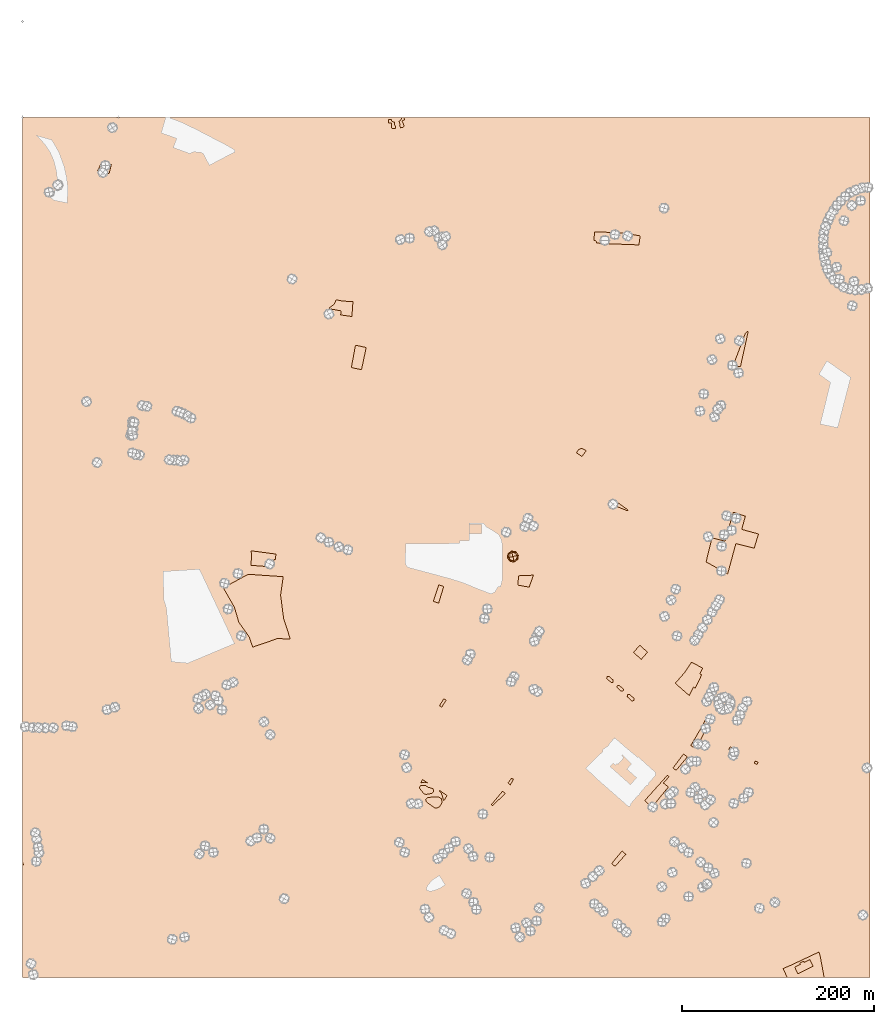
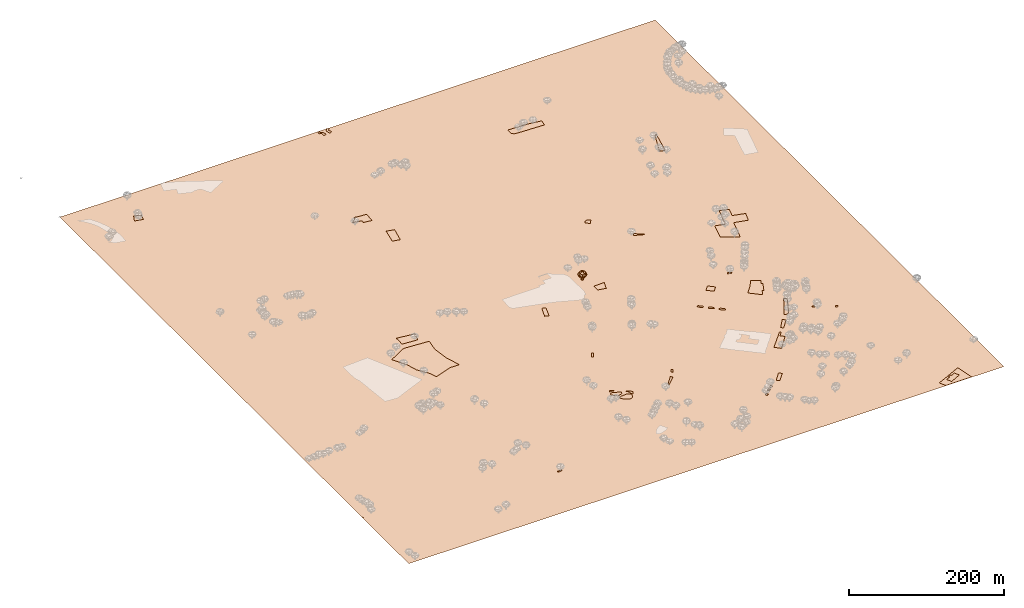
# Not in any storey, part 26 of 92: 3 geographic elements.
"""IFC4 model written with IfcOpenShell, lengths in metres."""

from ifc_helpers import new_model, si_unit, origin_with_axes, place, context, subcontext, project, spatial, triangles, material, element, save


model = new_model("IFC4")

# Units and contexts
model_context = context("Model", 3, precision=1e-05, world=origin_with_axes())
body_context = subcontext(model_context, "Body", "Model", "MODEL_VIEW")
ifc_project = project(units=[si_unit("VOLUMEUNIT", "CUBIC_METRE"), si_unit("LENGTHUNIT", "METRE"), si_unit("AREAUNIT", "SQUARE_METRE")], contexts=[model_context])

# Site
site_placement = place(None, origin_with_axes())
site = spatial("IfcSite", under=ifc_project, at=site_placement)

# Geographic elements
ifc_material_1 = material(Name="garden")
geographic_element_1_placement = place(site_placement, origin_with_axes())
element("IfcGeographicElement", 1, at=geographic_element_1_placement, inside=site, material=ifc_material_1, Name="cw_surface_garden", context=body_context, shape_type="Tessellation", body=[
    triangles([(388.47952636224693, -8.882966585345057, 0.0), (385.2042061517901, -3.819002392627082, 0.0), (385.13451909391256, -5.839946064550666, 0.0), (385.5526414411779, -11.438196694471047, 0.0), (385.85461869198065, -4.353250842880523, 0.0), (384.8557613656651, -3.098883801084529, 0.0), (389.4319256499774, -11.438196694471047, 0.0), (386.7141019025411, -4.794621202912855, 0.0), (381.99857299921086, -2.1000169780317557, 0.0), (386.04046034305804, -11.92598710613945, 0.0), (388.99056478668234, -8.929424623930094, 0.0), (387.92202040248924, -4.91078529284993, 0.0), (384.71638724991, -2.3323071709569394, 0.0), (381.90565692204075, -5.7237819746135905, 0.0), (384.9254579202799, -11.136200450193824, 0.0), (623.1354040214331, -120.67944704737984, 0.0), (616.3292395657398, -120.16839912620719, 0.0), (643.135771776744, -133.17677338760163, 0.0), (644.4366087280466, -123.69923854888171, 0.0), (617.9552857548681, -120.21485716479222, 0.0), (616.3292395657398, -132.16048954844808, 0.0), (643.646814949548, -129.50655035243474, 0.0), (627.734791315384, -121.07434037535265, 0.0), (740.8495293756547, -414.62210676459796, 0.0), (749.2178548013137, -414.62210676459796, 0.0), (741.5812529801062, -412.0669146424209, 0.0), (630.8242793715006, -410.48730334358066, 0.0), (631.7999070849776, -409.8368908033902, 0.0), (620.5337301930213, -401.72990608987783, 0.0), (617.862368787379, -405.3072130478746, 0.0), (757.1912963957373, -223.0274272337283, 0.0), (741.6509400379838, -258.5449206210551, 0.0), (749.0146056308729, -260.3335741000535, 0.0), (754.1482663782056, -237.10434587931582, 0.0), (754.2876404939607, -225.04837090565186, 0.0), (596.6366580932153, -119.58767364389423, 0.0), (598.9828080352341, -130.0175982736074, 0.0), (628.228428226632, -132.61346492138944, 0.0), (623.1412160211471, -120.67944704737984, 0.0), (597.7981090578412, -128.71675419975188, 0.0), (598.7040598037239, -131.13260069638554, 0.0), (627.7405998280146, -121.07434037535265, 0.0), (617.961087738492, -120.21485716479222, 0.0), (596.357909861705, -128.50769302611923, 0.0), (605.6960515911954, -131.7597842172835, 0.0), (628.228428226632, -121.14983943642196, 0.0), (577.9371266214677, -350.02165330134426, 0.0), (588.1347610582557, -347.8380875008986, 0.0), (583.465671200036, -345.3525634431246, 0.0), (580.2832765634864, -346.6069304849206, 0.0), (583.6979613929611, -353.9473765552544, 0.0), (332.49707704346656, -201.9817458199618, 0.0), (333.7282340594445, -191.71442432529625, 0.0), (323.8558058927518, -196.03505990065364, 0.0), (322.5549713156335, -197.1268428008765, 0.0), (332.31124488912644, -203.53810910603502, 0.0), (325.6909174103352, -194.0605742673151, 0.0), (320.3714245086623, -198.5438319711946, 0.0), (343.64711076798505, -207.92843173926997, 0.0), (327.1078970839161, -190.41359924491522, 0.0), (319.8836103551508, -199.8214280322831, 0.0), (331.753748426106, -206.2094653181491, 0.0), (344.71565515217816, -192.38808487825378, 0.0), (358.5138160695182, -240.2635304900473, 0.0), (345.3893062083984, -248.69574046712938, 0.0), (343.06637578893486, -261.12336075599916, 0.0), (353.6821420697254, -263.3766136143224, 0.0), (347.34056282244444, -237.80121645809137, 0.0), (628.228428226632, -409.4478284720836, 0.0), (628.228428226632, -407.2642626716379, 0.0), (620.539527873436, -401.72990608987783, 0.0), (617.868171661322, -405.3072130478746, 0.0), (78.25895872576271, -56.125411261577945, 0.0), (91.31378152900494, -54.476136646703274, 0.0), (87.66680650660507, -47.71643030378836, 0.0), (82.92802959050788, -45.90455017968175, 0.0), (90.19878860296406, -58.91291969270757, 0.0), (92.61462560286046, -49.36570491866302, 0.0), (704.5770833645838, -655.1782282548988, 0.0), (718.4913988751237, -626.8385588093836, 0.0), (706.5283399786298, -639.7540264903452, 0.0), (697.2134177716947, -655.5498925635791, 0.0), (711.4529395523299, -641.7052641109168, 0.0), (714.5424276084466, -624.7943861181675, 0.0), (699.9080124998386, -657.2224009461149, 0.0), (678.7694102605334, -678.8952658807793, 0.0), (681.8821273359426, -681.4737250091979, 0.0), (693.6593493297278, -667.3735773443178, 0.0), (689.594232966588, -664.4002248879266, 0.0), (750.4083562851612, -429.99406868635, 0.0), (732.9399723326543, -442.35201853663233, 0.0), (714.519198589154, -458.58925259571424, 0.0), (744.2758382115129, -444.8375449685906, 0.0), (754.078579320328, -416.2423634334106, 0.0), (733.543936330997, -475.22137760858465, 0.0), (763.3935015272631, -449.57630763958196, 0.0), (752.8009642657651, -421.2831069164812, 0.0), (741.5812529801062, -412.0611019738084, 0.0), (719.4670176854095, -438.82117436558923, 0.0), (713.2183640120357, -463.9784325552647, 0.0), (735.6345670607981, -476.5686749726566, 0.0), (767.8767402376682, -434.77928939592636, 0.0), (709.5945990154539, -574.7586227186953, 0.0), (687.3409991017393, -583.3534548242995, 0.0), (700.0241575963012, -594.5267080713733, 0.0), (706.6677140943849, -580.821453734466, 0.0), (689.8032941402207, -580.5194764836633, 0.0), (681.0691069123359, -590.5545077854036, 0.0), (701.9986432296397, -595.5720139395366, 0.0), (690.7324644086586, -579.4044835576224, 0.0), (695.6106011954051, -603.3770403957207, 0.0), (708.5260546312609, -581.8667785961038, 0.0), (697.9799849050851, -568.5331885678769, 0.0), (652.1254829652152, -558.149731473486, 0.0), (644.0184816324127, -550.9486690156447, 0.0), (637.4446098180222, -558.3820216664112, 0.0), (645.5516111508247, -565.5598551049601, 0.0), (656.3764338568793, -719.7787197051014, 0.0), (669.3383429571358, -695.2254183912157, 0.0), (668.7576127264542, -694.6214638896103, 0.0), (657.3752888090105, -703.8202315033454, 0.0), (673.8215864159095, -698.825954368505, 0.0), (674.5184617430536, -688.0475944494041, 0.0), (649.3379769082699, -712.833185956215, 0.0), (658.5832096831431, -717.5254858402526, 0.0), (673.1711643789816, -698.1755418283145, 0.0), (672.869187128179, -686.4912311633308, 0.0), (681.0691069123359, -538.05644934745, 0.0), (679.9773287604817, -540.1935381158362, 0.0), (684.4141141806703, -542.4235429613924, 0.0), (686.667348045519, -540.8671891720564, 0.0), (763.4167305465556, -674.0868209002791, 0.0), (766.413293028765, -675.3179779162571, 0.0), (767.435379374373, -673.0414960386413, 0.0), (764.4620459114562, -671.7406709582602, 0.0), (736.9586306572089, -659.7776120617664, 0.0), (739.9552026361555, -661.0552271163294, 0.0), (741.2095791746888, -658.1515617178156, 0.0), (738.2130071957421, -656.8507366374346, 0.0), (621.9216767086033, -402.7229513411269, 0.0), (617.862368787379, -405.3013959276665, 0.0), (630.8242793715006, -410.48151426842475, 0.0), (631.7999070849776, -409.83109579277345, 0.0), (619.7903948982672, -402.7229513411269, 0.0), (629.4305251559358, -769.001448435861, 0.0), (616.3292395657398, -776.690348789057, 0.0), (616.3292395657398, -780.0121175413616, 0.0), (618.1643487091391, -781.6613969046049, 0.0), (625.5280145988011, -765.6099736322043, 0.0), (635.7024179388852, -608.9056039677636, 0.0), (638.2344035965207, -606.4665379485746, 0.0), (631.1727176286188, -602.401421585435, 0.0), (630.8939670229242, -604.6314264309912, 0.0), (637.9556529908263, -608.7430008327159, 0.0), (633.3330366033896, -602.1691313925097, 0.0), (624.6453040011999, -598.8241146274381, 0.0), (626.8985392015273, -596.6405678204669, 0.0), (620.5569593607003, -593.1329479203476, 0.0), (620.3478964064293, -595.0145174765162, 0.0), (626.6662469311908, -598.8008856081457, 0.0), (622.5314439924298, -592.830970669545, 0.0), (264.2496010741268, -457.31164228951985, 0.0), (248.29112058846985, -453.64142400272164, 0.0), (238.23286382871345, -467.50927672630786, 0.0), (262.29834683426515, -461.12123469207324, 0.0), (261.5085530557666, -455.4068437140589, 0.0), (239.13880389076675, -455.5229935588901, 0.0), (261.3924067722118, -468.0203198991119, 0.0), (263.7385579013228, -461.30707159478203, 0.0), (264.4586646219438, -455.7785127711078, 0.0), (238.11671754515868, -452.2941266386497, 0.0), (260.7419882965605, -469.2282383990601, 0.0), (517.0068582064318, -488.18328908302544, 0.0), (528.667939852123, -490.3203778514116, 0.0), (532.9421173888953, -477.75336445331226, 0.0), (517.3785225151122, -478.42701550953257, 0.0), (508.9463125380301, -696.5727205036562, 0.0), (512.2448712645166, -690.6028055650555, 0.0), (510.2936146504706, -689.6039387420028, 0.0), (506.53047553813366, -694.6679219281953, 0.0), (490.4790712592076, -718.1991273997356, 0.0), (503.6500581523869, -705.5856559630513, 0.0), (500.83930883104324, -703.1930479824474, 0.0), (489.2247042174116, -717.1305925122798, 0.0), (621.9274950147443, -402.7229513411269, 0.0), (617.868171661322, -405.3013959276665, 0.0), (628.228428226632, -409.44200623254056, 0.0), (628.228428226632, -407.2584586094435, 0.0), (619.7961992560754, -402.7229513411269, 0.0), (437.2841422424784, -615.5027024272622, 0.0), (441.9532131072236, -608.3016494661581, 0.0), (439.5373761073272, -606.7917442186699, 0.0), (435.00767935833716, -613.9695681604815, 0.0), (428.5731840338861, -505.16385413365225, 0.0), (434.12495763174695, -506.99896565123566, 0.0), (439.44446003015713, -489.5538107180213, 0.0), (434.24110272820957, -487.83485379363765, 0.0), (601.1199157970948, -789.1179690779268, 0.0), (604.1164782793041, -787.5383957660355, 0.0), (602.536866980464, -784.5882533354622, 0.0), (599.7261366525947, -786.0517005443653, 0.0), (595.2429169356642, -794.7626777464321, 0.0), (598.2394794178736, -793.183066447592, 0.0), (596.6366580932153, -790.2329620039676, 0.0), (593.825927765346, -791.6964092128708, 0.0), (437.9113257633764, -707.7692027700225, 0.0), (438.70113141279654, -710.5799330978917, 0.0), (442.8126868210468, -707.699515712145, 0.0), (436.86601989521307, -705.1907626350785, 0.0), (439.1424827793544, -713.1119341877252, 0.0), (435.28642758984734, -703.2395060210324, 0.0), (439.885811396715, -712.78672791763, 0.0), (435.28642758984734, -702.4961774036718, 0.0), (417.4463698319229, -693.9710513494197, 0.0), (419.7692907546492, -693.7852002016051, 0.0), (417.3766827740453, -691.0209279123209, 0.0), (415.2163649863666, -694.8305250632428, 0.0), (422.41743694094527, -694.4588607545626, 0.0), (420.4197222883142, -697.2463620631393, 0.0), (414.5427234268836, -700.4984627510408, 0.0), (426.83098859347274, -705.4230528280036, 0.0), (423.16076555830585, -699.0582445614302, 0.0), (414.98407479344144, -697.5715683332345, 0.0), (421.0236767899197, -706.468358696167, 0.0), (428.9680773618589, -702.0548070436396, 0.0), (417.4695988512154, -696.967613831629, 0.0), (414.1246010796183, -699.1047026000152, 0.0), (418.7472139057784, -705.8876332138541, 0.0), (424.46160963216136, -705.9340912524391, 0.0), (428.3873518795459, -704.3544989470734, 0.0), (427.89952348092856, -700.4520047124557, 0.0), (420.4197222883142, -711.9040061910398, 0.0), (434.821847203997, -719.5232004928837, 0.0), (434.5895570110718, -709.5113982104359, 0.0), (423.300139674061, -709.6740013454835, 0.0), (430.2456734229474, -720.7543385153872, 0.0), (437.79518066691384, -714.3663012295211, 0.0), (431.8484947476057, -709.0003597860004, 0.0), (421.83669246515785, -710.4870170207216, 0.0), (421.5579442336476, -714.5056753452762, 0.0), (432.73121647419583, -720.6614224382171, 0.0), (436.773103818043, -716.9447413644652, 0.0), (436.88924891450563, -710.9051583614614, 0.0), (628.228428226632, -770.3603555612106, 0.0), (625.5338240017509, -765.6099736322043, 0.0), (614.7554450891755, -778.5951283710435, 0.0), (618.1701679055991, -781.6613969046049, 0.0), (628.228428226632, -767.9503495579804, 0.0), (613.9424484074118, -589.5556599558254, 0.0), (616.2653503366637, -587.2791780782096, 0.0), (609.6914808964575, -583.6554320751022, 0.0), (609.4591907035324, -585.5834596698558, 0.0), (616.0098501179205, -589.5324309365328, 0.0), (611.7356725811482, -583.330225805007, 0.0), (624.6511212686353, -598.8241146274381, 0.0), (626.904355133484, -596.6405678204669, 0.0), (620.562775886203, -593.1329479203476, 0.0), (620.3536957190959, -595.0145174765162, 0.0), (626.6720649405588, -598.8008856081457, 0.0), (622.5372615195415, -592.830970669545, 0.0), (272.37983142622187, -522.8877572983769, 0.0), (235.74733620966302, -476.8764642266511, 0.0), (240.16088993960176, -552.8302385718131, 0.0), (265.45752194825934, -543.9798967507285, 0.0), (269.2206563122277, -498.450610577691, 0.0), (236.3745250724757, -542.0286496334196, 0.0), (256.9091645005303, -547.0926138261376, 0.0), (279.32537229766126, -544.2818834982684, 0.0), (271.98493572406477, -479.3561810296019, 0.0), (235.74733620966302, -541.1459374035667, 0.0), (239.14462783675475, -455.5229935588901, 0.0), (238.23867709087207, -467.50927672630786, 0.0), (247.64652487171443, -453.55431518037466, 0.0), (238.122513000935, -452.2941266386497, 0.0), (247.64652487171443, -468.22938107274456, 0.0), (221.00259282802756, -511.15699809154546, 0.0), (236.38031756052163, -542.0286496334196, 0.0), (247.64652487171443, -550.2692154529699, 0.0), (235.33503068583278, -476.84742320416683, 0.0), (225.67164469929824, -526.929644642224, 0.0), (240.16670468562558, -552.8302385718131, 0.0), (247.64652487171443, -477.68948465025784, 0.0), (209.50409532390955, -490.9940289076319, 0.0), (601.1199157970948, -789.1121622613075, 0.0), (604.1164782793041, -787.5325746393913, 0.0), (602.536866980464, -784.5824623312815, 0.0), (599.7261366525947, -786.0459039014969, 0.0), (595.2429169356642, -794.7568650778196, 0.0), (598.2394794178736, -793.1772775208225, 0.0), (596.6366580932153, -790.2271652869059, 0.0), (593.825927765346, -791.6906067829281, 0.0), (587.6933906982233, -802.2366769542634, 0.0), (590.6899911673817, -800.6338603779737, 0.0), (589.1103798685414, -797.7069772375429, 0.0), (586.2996495406721, -799.1704191045313, 0.0), (273.0534801082579, -816.3368210578669, 0.0), (275.0047343481196, -814.9662946745025, 0.0), (268.38440449514405, -814.2926483666508, 0.0), (268.38440449514405, -816.7084877407316, 0.0), (275.09765279947396, -815.6399433565385, 0.0), (272.9837930503803, -814.5017119144678, 0.0), (395.93610803230604, -3.865460431212119, 0.0), (394.84433462882043, -2.703971479637234, 0.0), (394.1706835726001, -3.563464186934897, 0.0), (393.58995809028715, -3.911918469797156, 0.0), (394.333296204385, -11.089742411608787, 0.0), (393.91516436038245, -8.046721890814396, 0.0), (397.2601716287168, -9.696001254057684, 0.0), (392.8930780147744, -4.190666701307377, 0.0), (393.4738129938246, -8.255764070972578, 0.0), (397.19048457083926, -10.299955755663163, 0.0), (398.2357999357398, -9.022340701100168, 0.0), (397.0627186944714, 0.0, 0.0), (395.1230828603306, -1.890974797873573, 0.0), (396.7498222680915, 0.0, 0.0), (395.19276991820817, -0.9850240519908728, 0.0), (396.66571162948185, 0.0, 0.0), (398.7933058954975, -2.6110554024671604, 0.0), (397.6228246605845, 0.0, 0.0), (395.0533958024531, -0.17198938327824623, 0.0), (396.37479663284404, 1.1102230246251565e-16, 0.0), (395.4661738380483, 1.1102230246251565e-16, 0.0), (0.8127056459505266, -779.9888695285946, 0.0), (0.719789568780453, -778.9667926797238, 0.0), (0.25520918293008515, -777.8982577922679, 0.0), (0.0, -778.2920695975446, 0.0), (0.0, -780.50551833818, 0.0), (0.0, -777.9112148553148, 0.0), (0.0, -777.7747696795781, 0.0), (0.0, -777.6332329744286, 0.0), (0.0, -780.6661301067832, 0.0), (0.0, -777.5740710967289, 0.0), (821.4665815758447, -878.916368836146, 0.0), (824.8580373860268, -885.885131604325, 0.0), (830.8744103632125, -871.0648843413768, 0.0), (814.985609219334, -880.472722625482, 0.0), (801.7217252424591, -884.7469001622543, 0.0), (810.8740348176093, -882.4704372781131, 0.0), (805.6474674898437, -886.6981567763004, 0.0), (826.4376296913925, -873.0858280133004, 0.0), (793.4288893811322, -888.3242071202511, 0.0), (811.5244663512743, -883.8177298938164, 0.0), (815.6128117337065, -881.7735666993375, 0.0), (808.9924842549153, -893.5740129640465, 0.0), (830.0571115210081, -897.6930708238181, 0.0), (813.5326586908966, -897.6930708238181, 0.0), (798.0516929239776, -897.6930708238181, 0.0), (832.1055673791905, -874.5028171836185, 0.0), (836.1257148201179, -897.6930708238181, 0.0), (801.0230003561193, -897.6930708238181, 0.0), (836.4124860968701, -897.6930708238181, 0.0)], [[1, 2, 3], [3, 4, 1], [1, 5, 2], [2, 6, 3], [4, 7, 1], [1, 8, 5], [6, 9, 3], [4, 10, 7], [7, 11, 1], [1, 12, 8], [6, 13, 9], [9, 14, 3], [3, 15, 4], [16, 17, 18], [18, 19, 16], [16, 20, 17], [17, 21, 18], [18, 22, 19], [19, 23, 16], [24, 25, 26], [27, 28, 29], [29, 30, 27], [31, 32, 33], [33, 34, 31], [31, 35, 32], [36, 37, 38], [38, 39, 36], [36, 40, 37], [37, 41, 38], [38, 42, 39], [39, 43, 36], [36, 44, 40], [41, 45, 38], [38, 46, 42], [47, 48, 49], [49, 50, 47], [47, 51, 48], [52, 53, 54], [54, 55, 52], [52, 56, 53], [53, 57, 54], [55, 58, 52], [56, 59, 53], [53, 60, 57], [58, 61, 52], [56, 62, 59], [59, 63, 53], [64, 65, 66], [66, 67, 64], [64, 68, 65], [69, 70, 71], [71, 72, 69], [73, 74, 75], [75, 76, 73], [73, 77, 74], [74, 78, 75], [79, 80, 81], [81, 82, 79], [79, 83, 80], [80, 84, 81], [82, 85, 79], [86, 87, 88], [88, 89, 86], [90, 91, 92], [92, 93, 90], [90, 94, 91], [92, 95, 93], [93, 96, 90], [90, 97, 94], [94, 98, 91], [91, 99, 92], [92, 100, 95], [95, 101, 93], [96, 102, 90], [103, 104, 105], [105, 106, 103], [103, 107, 104], [104, 108, 105], [105, 109, 106], [103, 110, 107], [108, 111, 105], [109, 112, 106], [103, 113, 110], [114, 115, 116], [116, 117, 114], [118, 119, 120], [120, 121, 118], [118, 122, 119], [120, 123, 121], [121, 124, 118], [118, 125, 122], [122, 126, 119], [123, 127, 121], [128, 129, 130], [130, 131, 128], [132, 133, 134], [134, 135, 132], [136, 137, 138], [138, 139, 136], [140, 141, 142], [142, 143, 140], [140, 144, 141], [145, 146, 147], [147, 148, 145], [145, 149, 146], [150, 151, 152], [152, 153, 150], [150, 154, 151], [151, 155, 152], [156, 157, 158], [158, 159, 156], [156, 160, 157], [157, 161, 158], [162, 163, 164], [164, 165, 162], [162, 166, 163], [163, 167, 164], [164, 168, 165], [165, 169, 162], [162, 170, 166], [163, 171, 167], [164, 172, 168], [173, 174, 175], [175, 176, 173], [177, 178, 179], [179, 180, 177], [181, 182, 183], [183, 184, 181], [185, 186, 187], [187, 188, 185], [185, 189, 186], [190, 191, 192], [192, 193, 190], [194, 195, 196], [196, 197, 194], [198, 199, 200], [200, 201, 198], [202, 203, 204], [204, 205, 202], [206, 207, 208], [208, 209, 206], [207, 210, 208], [208, 211, 209], [210, 212, 208], [208, 213, 211], [214, 215, 216], [216, 217, 214], [215, 218, 216], [219, 220, 221], [221, 222, 219], [219, 223, 220], [220, 224, 221], [221, 225, 222], [219, 226, 223], [223, 227, 220], [220, 228, 224], [224, 229, 221], [221, 230, 225], [225, 231, 222], [232, 233, 234], [234, 235, 232], [232, 236, 233], [233, 237, 234], [234, 238, 235], [235, 239, 232], [232, 240, 236], [236, 241, 233], [233, 242, 237], [237, 243, 234], [244, 245, 246], [246, 247, 244], [244, 248, 245], [249, 250, 251], [251, 252, 249], [249, 253, 250], [250, 254, 251], [255, 256, 257], [257, 258, 255], [255, 259, 256], [256, 260, 257], [261, 262, 263], [263, 264, 261], [261, 265, 262], [262, 266, 263], [263, 267, 264], [264, 268, 261], [265, 269, 262], [262, 270, 266], [271, 272, 273], [273, 274, 271], [272, 275, 273], [276, 277, 278], [278, 279, 276], [276, 280, 277], [277, 281, 278], [278, 282, 279], [279, 283, 276], [284, 285, 286], [286, 287, 284], [288, 289, 290], [290, 291, 288], [292, 293, 294], [294, 295, 292], [296, 297, 298], [298, 299, 296], [296, 300, 297], [297, 301, 298], [302, 303, 304], [304, 305, 302], [305, 306, 302], [305, 307, 306], [306, 308, 302], [305, 309, 307], [307, 310, 306], [306, 311, 308], [308, 312, 302], [303, 302, 313], [314, 303, 315], [316, 314, 317], [302, 318, 319], [320, 316, 321], [313, 315, 303], [315, 317, 314], [317, 321, 316], [319, 313, 302], [321, 322, 320], [323, 324, 325], [323, 325, 326], [326, 327, 323], [325, 328, 326], [325, 329, 328], [325, 330, 329], [323, 327, 331], [325, 332, 330], [333, 334, 335], [335, 336, 333], [335, 337, 336], [337, 338, 336], [337, 339, 338], [335, 340, 337], [337, 341, 339], [339, 342, 338], [336, 343, 333], [344, 339, 341], [335, 334, 345], [334, 344, 346], [344, 341, 347], [348, 335, 349], [345, 349, 335], [346, 345, 334], [347, 350, 344], [349, 351, 348], [344, 350, 346]], closed=False),
])
ifc_material_2 = material(Name="tree")
geographic_element_2_placement = place(site_placement, origin_with_axes())
element("IfcGeographicElement", 2, at=geographic_element_2_placement, inside=site, material=ifc_material_2, Name="cw_instances_tree_182", context=body_context, shape_type="Tessellation", body=[
    triangles([(510.66445403126585, -459.5953097954998, 7.379881356641862), (510.66445403126585, -459.5953097954998, 7.379881356641862), (510.66445403126585, -459.5953097954998, 7.379881356641862), (510.66445403126585, -459.5953097954998, 0.0), (510.66445403126585, -459.5953097954998, 0.0), (510.66445403126585, -459.5953097954998, 0.0), (510.1555924868116, -457.66112781632216, 7.379881356641862), (510.1555924868116, -457.66112781632216, 7.379881356641862), (510.1555924868116, -457.66112781632216, 7.379881356641862), (510.1555924868116, -457.66112781632216, 0.0), (510.1555924868116, -457.66112781632216, 0.0), (510.1555924868116, -457.66112781632216, 0.0), (512.5986360104436, -459.0864482510456, 7.379881356641862), (512.5986360104436, -459.0864482510456, 7.379881356641862), (512.5986360104436, -459.0864482510456, 7.379881356641862), (512.5986360104436, -459.0864482510456, 0.0), (512.5986360104436, -459.0864482510456, 0.0), (512.5986360104436, -459.0864482510456, 0.0), (512.0897744659893, -457.152266271868, 7.379881356641862), (512.0897744659893, -457.152266271868, 7.379881356641862), (512.0897744659893, -457.152266271868, 7.379881356641862), (512.0897744659893, -457.152266271868, 0.0), (512.0897744659893, -457.152266271868, 0.0), (512.0897744659893, -457.152266271868, 0.0), (509.12336543430183, -462.58582480694207, 10.992814628859097), (509.12336543430183, -462.58582480694207, 10.992814628859097), (509.12336543430183, -462.58582480694207, 10.992814628859097), (509.12336543430183, -462.58582480694207, 10.992814628859097), (509.12336543430183, -462.58582480694207, 10.992814628859097), (509.12336543430183, -462.58582480694207, 10.992814628859097), (509.12336532432676, -462.58582533220914, 5.826897885846483), (509.12336532432676, -462.58582533220914, 5.826897885846483), (509.12336532432676, -462.58582533220914, 5.826897885846483), (509.12336532432676, -462.58582533220914, 5.826897885846483), (509.12336532432676, -462.58582533220914, 5.826897885846483), (509.12336532432676, -462.58582533220914, 5.826897885846483), (507.3423502215096, -455.8161895559256, 10.992814628859097), (507.3423502215096, -455.8161895559256, 10.992814628859097), (507.3423502215096, -455.8161895559256, 10.992814628859097), (507.3423502215096, -455.8161895559256, 10.992814628859097), (507.3423502215096, -455.8161895559256, 10.992814628859097), (507.3423502215096, -455.8161895559256, 10.992814628859097), (507.3423502215096, -455.8161895559256, 5.826897885846483), (507.3423502215096, -455.8161895559256, 5.826897885846483), (507.3423502215096, -455.8161895559256, 5.826897885846483), (507.3423502215096, -455.8161895559256, 5.826897885846483), (507.3423502215096, -455.8161895559256, 5.826897885846483), (507.3423502215096, -455.8161895559256, 5.826897885846483), (515.8930017969159, -460.8048100462018, 10.992814628859097), (515.8930017969159, -460.8048100462018, 10.992814628859097), (515.8930017969159, -460.8048100462018, 10.992814628859097), (515.8930017969159, -460.8048100462018, 10.992814628859097), (515.8930017969159, -460.8048100462018, 10.992814628859097), (515.8930017969159, -460.8048100462018, 10.992814628859097), (515.8930013327122, -460.8048101683286, 5.826897885846483), (515.8930013327122, -460.8048101683286, 5.826897885846483), (515.8930013327122, -460.8048101683286, 5.826897885846483), (515.8930013327122, -460.8048101683286, 5.826897885846483), (515.8930013327122, -460.8048101683286, 5.826897885846483), (515.8930013327122, -460.8048101683286, 5.826897885846483), (514.1119866330353, -454.03517403781643, 10.992814628859097), (514.1119866330353, -454.03517403781643, 10.992814628859097), (514.1119866330353, -454.03517403781643, 10.992814628859097), (514.1119866330353, -454.03517403781643, 10.992814628859097), (514.1119866330353, -454.03517403781643, 10.992814628859097), (514.1119866330353, -454.03517403781643, 10.992814628859097), (514.1119866940987, -454.03517426991823, 5.826897885846483), (514.1119866940987, -454.03517426991823, 5.826897885846483), (514.1119866940987, -454.03517426991823, 5.826897885846483), (514.1119866940987, -454.03517426991823, 5.826897885846483), (514.1119866940987, -454.03517426991823, 5.826897885846483), (514.1119866940987, -454.03517426991823, 5.826897885846483), (515.7442287455317, -457.2248500063283, 5.260880065723697), (515.7442287455317, -457.2248500063283, 5.260880065723697), (515.7442287455317, -457.2248500063283, 5.260880065723697), (515.7442287455317, -457.2248500063283, 5.260880065723697), (512.7033254894285, -462.43705201005224, 5.260880065723697), (512.7033254894285, -462.43705201005224, 5.260880065723697), (512.7033254894285, -462.43705201005224, 5.260880065723697), (512.7033254894285, -462.43705201005224, 5.260880065723697), (508.57677320714225, -463.5227015457428, 8.4098567001457), (508.57677320714225, -463.5227015457428, 8.4098567001457), (508.57677320714225, -463.5227015457428, 8.4098567001457), (508.57677320714225, -463.5227015457428, 8.4098567001457), (514.6585792047525, -453.09829770470026, 8.4098567001457), (514.6585792047525, -453.09829770470026, 8.4098567001457), (514.6585792047525, -453.09829770470026, 8.4098567001457), (514.6585792047525, -453.09829770470026, 8.4098567001457), (506.4054735438358, -455.2695965785237, 8.4098567001457), (506.4054735438358, -455.2695965785237, 8.4098567001457), (506.4054735438358, -455.2695965785237, 8.4098567001457), (506.4054735438358, -455.2695965785237, 8.4098567001457), (516.8298778297401, -461.3514024590959, 8.4098567001457), (516.8298778297401, -461.3514024590959, 8.4098567001457), (516.8298778297401, -461.3514024590959, 8.4098567001457), (516.8298778297401, -461.3514024590959, 8.4098567001457), (510.53202628065475, -454.1839469232507, 11.558832006188974), (510.53202628065475, -454.1839469232507, 11.558832006188974), (510.53202628065475, -454.1839469232507, 11.558832006188974), (510.53202628065475, -454.1839469232507, 11.558832006188974), (507.4911232296405, -459.3961494313936, 11.558833740461198), (507.4911232296405, -459.3961494313936, 11.558833740461198), (507.4911232296405, -459.3961494313936, 11.558833740461198), (507.4911232296405, -459.3961494313936, 11.558833740461198), (510.5320264485918, -454.1839473650619, 5.260880065723697), (510.5320264485918, -454.1839473650619, 5.260880065723697), (510.5320264485918, -454.1839473650619, 5.260880065723697), (510.5320264485918, -454.1839473650619, 5.260880065723697), (515.744228755709, -457.224850045012, 11.558832006188974), (515.744228755709, -457.224850045012, 11.558832006188974), (515.744228755709, -457.224850045012, 11.558832006188974), (515.744228755709, -457.224850045012, 11.558832006188974), (512.7033254604157, -462.4370520176852, 11.558833740461198), (512.7033254604157, -462.4370520176852, 11.558833740461198), (512.7033254604157, -462.4370520176852, 11.558833740461198), (512.7033254604157, -462.4370520176852, 11.558833740461198), (507.4911236689074, -459.39614925378567, 5.260880065723697), (507.4911236689074, -459.39614925378567, 5.260880065723697), (507.4911236689074, -459.39614925378567, 5.260880065723697), (507.4911236689074, -459.39614925378567, 5.260880065723697), (511.6176760616369, -458.31049982346246, 12.74667634206937), (511.6176760616369, -458.31049982346246, 12.74667634206937), (511.6176760616369, -458.31049982346246, 12.74667634206937), (511.6176760616369, -458.31049982346246, 12.74667634206937), (511.6176760616369, -458.31049982346246, 12.74667634206937), (511.6176760616369, -458.31049982346246, 12.74667634206937), (511.6176760616369, -458.31049982346246, 12.74667634206937), (511.6176760616369, -458.31049982346246, 12.74667634206937), (510.1225027430578, -452.6273485614729, 8.4098567001457), (510.1225027430578, -452.6273485614729, 8.4098567001457), (510.1225027430578, -452.6273485614729, 8.4098567001457), (510.1225027430578, -452.6273485614729, 8.4098567001457), (510.1225027430578, -452.6273485614729, 8.4098567001457), (510.1225027430578, -452.6273485614729, 8.4098567001457), (510.1225027430578, -452.6273485614729, 8.4098567001457), (510.1225027430578, -452.6273485614729, 8.4098567001457), (517.3008271149424, -456.8153264977441, 8.4098567001457), (517.3008271149424, -456.8153264977441, 8.4098567001457), (517.3008271149424, -456.8153264977441, 8.4098567001457), (517.3008271149424, -456.8153264977441, 8.4098567001457), (517.3008271149424, -456.8153264977441, 8.4098567001457), (517.3008271149424, -456.8153264977441, 8.4098567001457), (517.3008271149424, -456.8153264977441, 8.4098567001457), (517.3008271149424, -456.8153264977441, 8.4098567001457), (511.61767592624415, -458.3104998590828, 4.073037906908434), (511.61767592624415, -458.3104998590828, 4.073037906908434), (511.61767592624415, -458.3104998590828, 4.073037906908434), (511.61767592624415, -458.3104998590828, 4.073037906908434), (511.61767592624415, -458.3104998590828, 4.073037906908434), (511.61767592624415, -458.3104998590828, 4.073037906908434), (511.61767592624415, -458.3104998590828, 4.073037906908434), (511.61767592624415, -458.3104998590828, 4.073037906908434), (505.93452534020565, -459.80567291710446, 8.4098567001457), (505.93452534020565, -459.80567291710446, 8.4098567001457), (505.93452534020565, -459.80567291710446, 8.4098567001457), (505.93452534020565, -459.80567291710446, 8.4098567001457), (505.93452534020565, -459.80567291710446, 8.4098567001457), (505.93452534020565, -459.80567291710446, 8.4098567001457), (505.93452534020565, -459.80567291710446, 8.4098567001457), (505.93452534020565, -459.80567291710446, 8.4098567001457), (513.1128491975068, -463.9936508233122, 8.4098567001457), (513.1128491975068, -463.9936508233122, 8.4098567001457), (513.1128491975068, -463.9936508233122, 8.4098567001457), (513.1128491975068, -463.9936508233122, 8.4098567001457), (513.1128491975068, -463.9936508233122, 8.4098567001457), (513.1128491975068, -463.9936508233122, 8.4098567001457), (513.1128491975068, -463.9936508233122, 8.4098567001457), (513.1128491975068, -463.9936508233122, 8.4098567001457)], [[15, 8, 2], [7, 24, 11], [19, 16, 22], [4, 23, 17], [3, 12, 6], [14, 5, 18], [26, 127, 101], [54, 123, 114], [124, 66, 98], [128, 38, 102], [45, 133, 108], [40, 135, 89], [130, 63, 88], [131, 70, 105], [68, 141, 73], [61, 140, 86], [137, 49, 93], [142, 56, 74], [59, 145, 75], [31, 149, 79], [150, 43, 107], [146, 71, 76], [35, 154, 120], [30, 157, 83], [158, 42, 91], [153, 47, 119], [58, 164, 77], [51, 162, 96], [167, 28, 81], [165, 33, 80], [15, 21, 8], [7, 20, 24], [19, 13, 16], [4, 10, 23], [3, 9, 12], [14, 1, 5], [25, 115, 126], [53, 111, 121], [122, 112, 65], [125, 99, 37], [46, 90, 136], [39, 100, 134], [132, 97, 64], [129, 87, 69], [67, 85, 138], [62, 110, 144], [143, 109, 50], [139, 94, 55], [60, 78, 147], [32, 117, 151], [152, 118, 44], [148, 106, 72], [36, 84, 160], [29, 104, 156], [155, 103, 41], [159, 92, 48], [57, 95, 161], [52, 113, 163], [166, 116, 27], [168, 82, 34]], closed=True),
])
ifc_material_3 = material(Name="topography")
geographic_element_3_placement = place(site_placement, origin_with_axes())
element("IfcGeographicElement", 3, at=geographic_element_3_placement, inside=site, material=ifc_material_3, Name="cw_topography_topography", context=body_context, shape_type="Tessellation", body=[
    triangles([(0.0, 0.0, -0.5), (442.19695711096216, 0.0, -0.5), (0.0, -448.84653541190903, -0.5), (442.19695711096216, -448.84653541190903, -0.5), (884.3939142219243, 0.0, -0.5), (884.3939142219243, -448.84653541190903, -0.5), (0.0, -897.6930708238181, -0.5), (442.19695711096216, -897.6930708238181, -0.5), (884.3939142219243, -897.6930708238181, -0.5)], [[1, 2, 3], [2, 4, 3], [2, 5, 4], [5, 6, 4], [3, 4, 7], [4, 8, 7], [4, 6, 8], [6, 9, 8]], closed=False),
])

save(model, "model.ifc")
